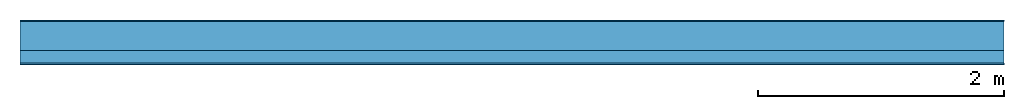
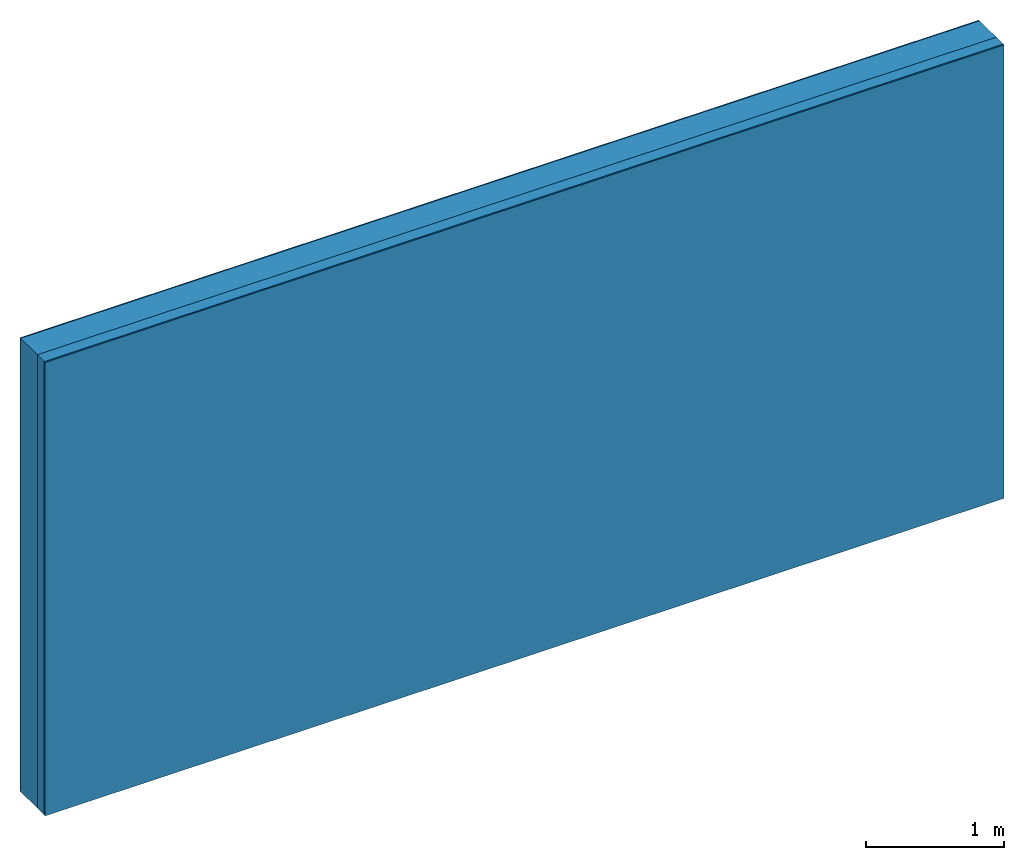
# One storey: 3 plates, 1 member, 1 element without a shape of its own.
"""IFC4 building model written with IfcOpenShell, lengths in metres."""

from ifc_helpers import new_model, si_unit, derived_unit, direction, frame, frame_2d, origin, origin_with_axes, place, context, project, spatial, rectangle, extrude, material, layer, layer_set, type_object, element, aggregate, save


model = new_model("IFC4")

# Units and contexts
plan_context = context("Plan", 3, precision=1e-05, world=origin(), true_north=direction((0.0, 1.0)))
model_context = context("Model", 3, precision=1e-05, world=origin(), true_north=direction((0.0, 1.0)))
ifc_project = project(units=[si_unit("LENGTHUNIT", "METRE"), derived_unit("SOUNDPRESSUREUNIT", [(si_unit("PRESSUREUNIT", "PASCAL", prefix="MICRO"), 0)]), si_unit("ENERGYUNIT", "JOULE", prefix="MEGA"), si_unit("MASSUNIT", "GRAM", prefix="KILO"), derived_unit("THERMALTRANSMITTANCEUNIT", [(si_unit("POWERUNIT", "WATT"), 1), (si_unit("AREAUNIT", "SQUARE_METRE"), -1), (si_unit("THERMODYNAMICTEMPERATUREUNIT", "KELVIN"), -1)]), derived_unit("AREADENSITYUNIT", [(si_unit("MASSUNIT", "GRAM", prefix="KILO"), 1), (si_unit("AREAUNIT", "SQUARE_METRE"), -1)]), derived_unit("USERDEFINED", [(si_unit("ENERGYUNIT", "JOULE", prefix="MEGA"), 1), (si_unit("AREAUNIT", "SQUARE_METRE"), -1)])], contexts=[plan_context, model_context])

# Site, building, storey
site = spatial("IfcSite", under=ifc_project)
building_placement = place(None, origin())
building = spatial("IfcBuilding", under=site, at=building_placement)
storey_placement = place(building_placement, origin())
storey = spatial("IfcBuildingStorey", under=building, at=storey_placement)

# Wall, member, plates
ifc_material_1 = material(Category="04.011")
ifc_layer_1 = layer(ifc_material_1, 0.01, Name="Surface 1")
ifc_material_2 = material(Name="Mineral wool", Category="10.008")
ifc_layer_2 = layer(ifc_material_2, 0.24, Name="outside 1st layer")
ifc_material_3 = material(Name="of the art")
ifc_layer_3 = layer(ifc_material_3, 0.0, Name="Bond")
ifc_layer_4 = layer(None, 0.1, Name="Support")
ifc_layer_5 = layer(ifc_material_3, 0.0, Name="Bond")
ifc_material_4 = material(Name="Plasterboard type A", Category="03.008")
ifc_layer_6 = layer(ifc_material_4, 0.0125, Name="1st layer")
ifc_material_5 = material(Name="joints", Category="04.017")
ifc_layer_7 = layer(ifc_material_5, 0.0, Name="Surface")
ifc_layer_set = layer_set([ifc_layer_1, ifc_layer_2, ifc_layer_3, ifc_layer_4, ifc_layer_5, ifc_layer_6, ifc_layer_7])
wall_type = type_object("IfcWallType", Name="D1027", PredefinedType="NOTDEFINED", material=ifc_layer_set)
wall_placement = place(None, frame((0.0, 0.0, 0.0), z_axis=(0.0, -1.0, 0.0), x_axis=(1.0, 0.0, 0.0)))
wall = element("IfcWall", 1, at=wall_placement, inside=storey, type_object=wall_type, material=ifc_layer_set, Name="Wall #1")
ifc_material_6 = material(Name="Solid timber panel")
member_placement = place(wall_placement, origin())
member = element("IfcMember", 2, at=member_placement, material=ifc_material_6, Name="Support", context=plan_context, shape_type="SweptSolid", body=[
    extrude(rectangle(XDim=1.0, YDim=0.1, at=frame_2d((0.5, 0.05), x_axis=(1.0, 0.0))), frame((0.0, 4.0, 0.25), z_axis=(0.0, -1.0, 0.0), x_axis=(1.0, 0.0, 0.0)), (0.0, 0.0, 1.0), 4.0),
    extrude(rectangle(XDim=1.0, YDim=0.1, at=frame_2d((0.5, 0.05), x_axis=(1.0, 0.0))), frame((1.0, 4.0, 0.25), z_axis=(0.0, -1.0, 0.0), x_axis=(1.0, 0.0, 0.0)), (0.0, 0.0, 1.0), 4.0),
    extrude(rectangle(XDim=1.0, YDim=0.1, at=frame_2d((0.5, 0.05), x_axis=(1.0, 0.0))), frame((2.0, 4.0, 0.25), z_axis=(0.0, -1.0, 0.0), x_axis=(1.0, 0.0, 0.0)), (0.0, 0.0, 1.0), 4.0),
    extrude(rectangle(XDim=1.0, YDim=0.1, at=frame_2d((0.5, 0.05), x_axis=(1.0, 0.0))), frame((3.0, 4.0, 0.25), z_axis=(0.0, -1.0, 0.0), x_axis=(1.0, 0.0, 0.0)), (0.0, 0.0, 1.0), 4.0),
    extrude(rectangle(XDim=1.0, YDim=0.1, at=frame_2d((0.5, 0.05), x_axis=(1.0, 0.0))), frame((4.0, 4.0, 0.25), z_axis=(0.0, -1.0, 0.0), x_axis=(1.0, 0.0, 0.0)), (0.0, 0.0, 1.0), 4.0),
    extrude(rectangle(XDim=1.0, YDim=0.1, at=frame_2d((0.5, 0.05), x_axis=(1.0, 0.0))), frame((5.0, 4.0, 0.25), z_axis=(0.0, -1.0, 0.0), x_axis=(1.0, 0.0, 0.0)), (0.0, 0.0, 1.0), 4.0),
    extrude(rectangle(XDim=1.0, YDim=0.1, at=frame_2d((0.5, 0.05), x_axis=(1.0, 0.0))), frame((6.0, 4.0, 0.25), z_axis=(0.0, -1.0, 0.0), x_axis=(1.0, 0.0, 0.0)), (0.0, 0.0, 1.0), 4.0),
    extrude(rectangle(XDim=1.0, YDim=0.1, at=frame_2d((0.5, 0.05), x_axis=(1.0, 0.0))), frame((7.0, 4.0, 0.25), z_axis=(0.0, -1.0, 0.0), x_axis=(1.0, 0.0, 0.0)), (0.0, 0.0, 1.0), 4.0),
])
plate_1_placement = place(wall_placement, origin())
plate_1 = element("IfcPlate", 3, at=plate_1_placement, material=ifc_material_1, Name="Surface 1", context=plan_context, shape_type="SweptSolid", body=[
    extrude(rectangle(XDim=8.0, YDim=4.0, at=frame_2d((4.0, 2.0), x_axis=(1.0, 0.0))), origin_with_axes(), (0.0, 0.0, 1.0), 0.01),
])
plate_2_placement = place(wall_placement, origin())
plate_2 = element("IfcPlate", 4, at=plate_2_placement, material=ifc_material_2, Name="outside 1st layer", context=plan_context, shape_type="SweptSolid", body=[
    extrude(rectangle(XDim=8.0, YDim=4.0, at=frame_2d((4.0, 2.0), x_axis=(1.0, 0.0))), frame((0.0, 0.0, 0.01), z_axis=(0.0, 0.0, 1.0), x_axis=(1.0, 0.0, 0.0)), (0.0, 0.0, 1.0), 0.24),
])
plate_3_placement = place(wall_placement, origin())
plate_3 = element("IfcPlate", 5, at=plate_3_placement, material=ifc_material_4, Name="1st layer", context=plan_context, shape_type="SweptSolid", body=[
    extrude(rectangle(XDim=8.0, YDim=4.0, at=frame_2d((4.0, 2.0), x_axis=(1.0, 0.0))), frame((0.0, 0.0, 0.35), z_axis=(0.0, 0.0, 1.0), x_axis=(1.0, 0.0, 0.0)), (0.0, 0.0, 1.0), 0.0125),
])
aggregate(wall, [plate_1, plate_2, member, plate_3])

save(model, "model.ifc")
